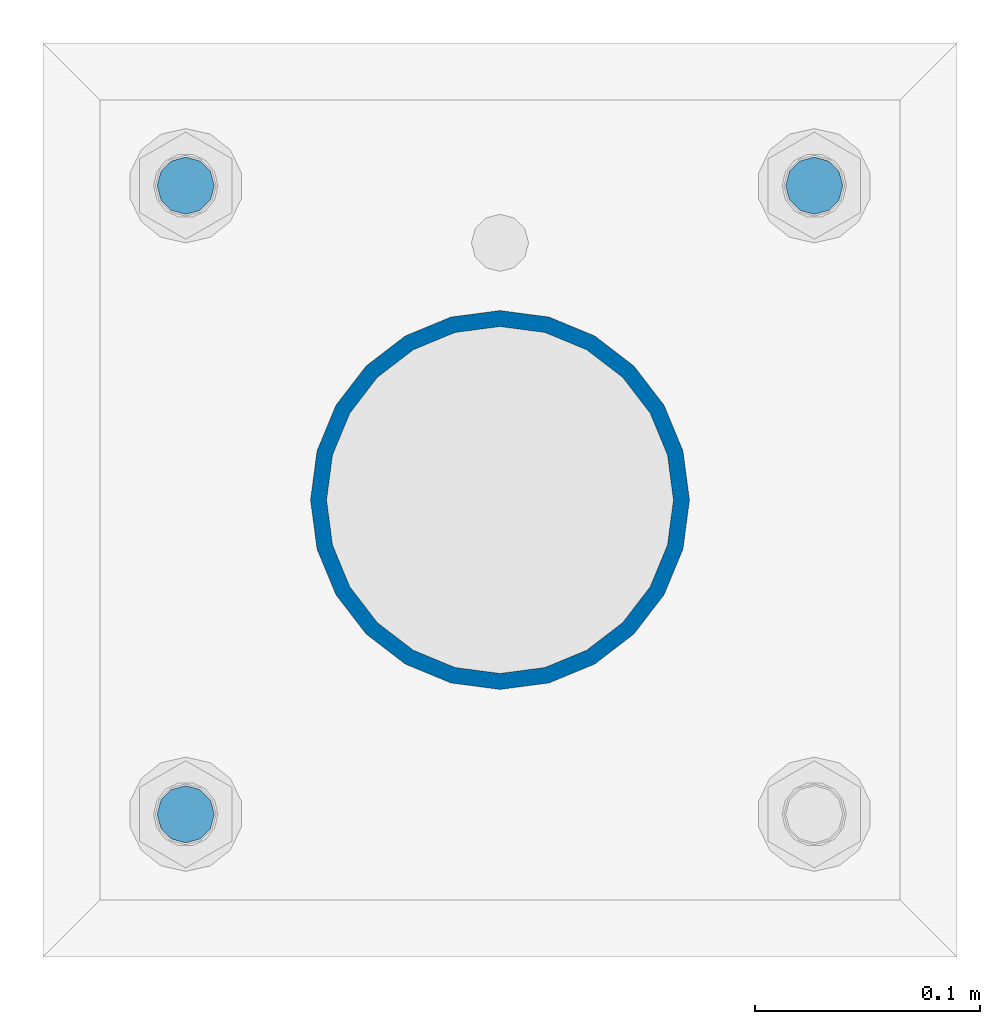
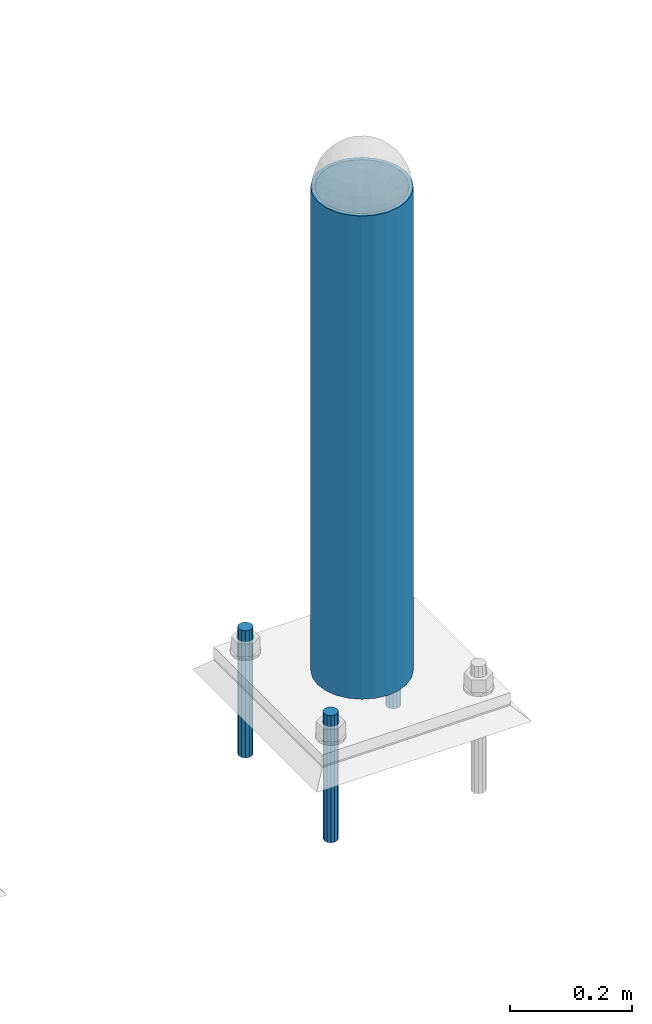
# One storey, part 1441 of 3843: 4 columns, 2 elements without a shape of their own.
"""IFC2X3 building model written with IfcOpenShell, lengths in millimetres."""

from ifc_helpers import new_model, si_unit, frame, origin_with_axes, place, context, subcontext, project, spatial, faceted_brep, material, type_object, element, aggregate, save


model = new_model("IFC2X3")

# Units and contexts
model_context = context("Model", 3, precision=1e-05, world=origin_with_axes())
body_context = subcontext(model_context, "Body", "Model", "MODEL_VIEW")
ifc_project = project(units=[si_unit("LENGTHUNIT", "METRE", prefix="MILLI"), si_unit("AREAUNIT", "SQUARE_METRE"), si_unit("VOLUMEUNIT", "CUBIC_METRE"), si_unit("MASSUNIT", "GRAM", prefix="KILO"), si_unit("TIMEUNIT", "SECOND"), si_unit("PLANEANGLEUNIT", "RADIAN"), si_unit("SOLIDANGLEUNIT", "STERADIAN"), si_unit("THERMODYNAMICTEMPERATUREUNIT", "DEGREE_CELSIUS"), si_unit("LUMINOUSINTENSITYUNIT", "LUMEN")], contexts=[model_context])

# Site, building, storey
site_placement = place(None, origin_with_axes())
site = spatial("IfcSite", under=ifc_project, at=site_placement, CompositionType="ELEMENT")
building_placement = place(site_placement, origin_with_axes())
building = spatial("IfcBuilding", under=site, at=building_placement, Name="Undefined", CompositionType="ELEMENT")
storey_placement = place(building_placement, origin_with_axes())
storey = spatial("IfcBuildingStorey", under=building, at=storey_placement, Name="Undefined", CompositionType="ELEMENT", Elevation=0.0)

# Assembly, column
assembly_1_placement = place(storey_placement, origin_with_axes())
assembly_1 = element("IfcElementAssembly", 1, at=assembly_1_placement, inside=storey, Name="PIPE_BOLLARD", AssemblyPlace="NOTDEFINED", PredefinedType="RIGID_FRAME")
ifc_material_1 = material()
column_type_1 = type_object("IfcColumnType", Name="PIPE6SCH40", PredefinedType="NOTDEFINED")
column_1_placement = place(assembly_1_placement, frame((37106.2721557617, 11565.3447954918, 30480.0), z_axis=(-1.0, 0.0, 0.0), x_axis=(0.0, 0.0, 1.0)))
column_1 = element("IfcColumn", 2, at=column_1_placement, type_object=column_type_1, material=ifc_material_1, Name="PIPE_BOLLARD", ObjectType="PIPE6SCH40", context=body_context, shape_type="Brep", body=[
    faceted_brep([(50.7999999999993, -77.0890000000072, 0.0), (50.7999999999993, -74.4622560228017, 19.9521013679114), (1016.0, -74.4622560228017, 19.9521013679114), (1016.0, -77.0890000000072, 0.0), (50.7999999999993, -66.7610323523404, 38.5445000000036), (1016.0, -66.7610323523404, 38.5445000000036), (50.7999999999993, -54.5101546548831, 54.5101546548904), (1016.0, -54.5101546548831, 54.5101546548904), (50.7999999999993, -38.5445000000036, 66.7610323523404), (1016.0, -38.5445000000036, 66.7610323523404), (50.7999999999993, -19.9521013679041, 74.4622560227945), (1016.0, -19.9521013679041, 74.4622560227945), (50.7999999999993, 0.0, 77.0889999999999), (1016.0, 0.0, 77.0889999999999), (50.7999999999993, 19.9521013679041, 74.4622560227945), (1016.0, 19.9521013679041, 74.4622560227945), (50.7999999999993, 38.5445000000036, 66.7610323523404), (1016.0, 38.5445000000036, 66.7610323523404), (50.7999999999993, 54.5101546548831, 54.5101546548904), (1016.0, 54.5101546548831, 54.5101546548904), (50.7999999999993, 66.7610323523404, 38.5445000000036), (1016.0, 66.7610323523404, 38.5445000000036), (50.7999999999993, 74.4622560228017, 19.9521013679114), (1016.0, 74.4622560228017, 19.9521013679114), (50.7999999999993, 77.0890000000072, 0.0), (1016.0, 77.0890000000072, 0.0), (50.7999999999993, 74.4622560228017, -19.9521013679114), (1016.0, 74.4622560228017, -19.9521013679114), (50.7999999999993, 66.7610323523404, -38.5445000000036), (1016.0, 66.7610323523404, -38.5445000000036), (50.7999999999993, 54.5101546548831, -54.5101546548904), (1016.0, 54.5101546548831, -54.5101546548904), (50.7999999999993, 38.5445000000036, -66.7610323523404), (1016.0, 38.5445000000036, -66.7610323523404), (50.7999999999993, 19.9521013679041, -74.4622560227945), (1016.0, 19.9521013679041, -74.4622560227945), (50.7999999999993, 0.0, -77.0889999999999), (1016.0, 0.0, -77.0889999999999), (50.7999999999993, -19.9521013679041, -74.4622560227945), (1016.0, -19.9521013679041, -74.4622560227945), (50.7999999999993, -38.5445000000036, -66.7610323523404), (1016.0, -38.5445000000036, -66.7610323523404), (50.7999999999993, -54.5101546548831, -54.5101546548904), (1016.0, -54.5101546548831, -54.5101546548904), (50.7999999999993, -66.7610323523404, -38.5445000000036), (1016.0, -66.7610323523404, -38.5445000000036), (50.7999999999993, -74.4622560228017, -19.9521013679114), (1016.0, -74.4622560228017, -19.9521013679114), (50.7999999999993, -84.2010000000009, 0.0), (50.7999999999993, -81.3319204993604, -21.7928224166753), (1016.0, -81.3319204993604, -21.7928224166753), (1016.0, -84.2010000000009, 0.0), (50.7999999999993, -72.9202050240565, -42.1005000000005), (1016.0, -72.9202050240565, -42.1005000000005), (50.7999999999993, -59.5390980826924, -59.5390980826851), (1016.0, -59.5390980826924, -59.5390980826851), (50.7999999999993, -42.1005000000005, -72.9202050240565), (1016.0, -42.1005000000005, -72.9202050240565), (50.7999999999993, -21.7928224166826, -81.3319204993677), (1016.0, -21.7928224166826, -81.3319204993677), (50.7999999999993, 0.0, -84.2010000000009), (1016.0, 0.0, -84.2010000000009), (50.7999999999993, 21.7928224166826, -81.3319204993677), (1016.0, 21.7928224166826, -81.3319204993677), (50.7999999999993, 42.1005000000005, -72.9202050240565), (1016.0, 42.1005000000005, -72.9202050240565), (50.7999999999993, 59.5390980826924, -59.5390980826851), (1016.0, 59.5390980826924, -59.5390980826851), (50.7999999999993, 72.9202050240565, -42.1005000000005), (1016.0, 72.9202050240565, -42.1005000000005), (50.7999999999993, 81.3319204993604, -21.7928224166753), (1016.0, 81.3319204993604, -21.7928224166753), (50.7999999999993, 84.2010000000009, 0.0), (1016.0, 84.2010000000009, 0.0), (50.7999999999993, 81.3319204993604, 21.7928224166753), (1016.0, 81.3319204993604, 21.7928224166753), (50.7999999999993, 72.9202050240565, 42.1005000000005), (1016.0, 72.9202050240565, 42.1005000000005), (50.7999999999993, 59.5390980826924, 59.5390980826851), (1016.0, 59.5390980826924, 59.5390980826851), (50.7999999999993, 42.1005000000005, 72.9202050240565), (1016.0, 42.1005000000005, 72.9202050240565), (50.7999999999993, 21.7928224166826, 81.3319204993677), (1016.0, 21.7928224166826, 81.3319204993677), (50.7999999999993, 0.0, 84.2010000000009), (1016.0, 0.0, 84.2010000000009), (50.7999999999993, -21.7928224166826, 81.3319204993677), (1016.0, -21.7928224166826, 81.3319204993677), (50.7999999999993, -42.1005000000005, 72.9202050240565), (1016.0, -42.1005000000005, 72.9202050240565), (50.7999999999993, -59.5390980826924, 59.5390980826851), (1016.0, -59.5390980826924, 59.5390980826851), (50.7999999999993, -72.9202050240565, 42.1005000000005), (1016.0, -72.9202050240565, 42.1005000000005), (50.7999999999993, -81.3319204993604, 21.7928224166753), (1016.0, -81.3319204993604, 21.7928224166753)], [[[0, 1, 2, 3]], [[1, 4, 5, 2]], [[4, 6, 7, 5]], [[6, 8, 9, 7]], [[8, 10, 11, 9]], [[10, 12, 13, 11]], [[12, 14, 15, 13]], [[14, 16, 17, 15]], [[16, 18, 19, 17]], [[18, 20, 21, 19]], [[20, 22, 23, 21]], [[22, 24, 25, 23]], [[24, 26, 27, 25]], [[26, 28, 29, 27]], [[28, 30, 31, 29]], [[30, 32, 33, 31]], [[32, 34, 35, 33]], [[34, 36, 37, 35]], [[36, 38, 39, 37]], [[38, 40, 41, 39]], [[40, 42, 43, 41]], [[42, 44, 45, 43]], [[44, 46, 47, 45]], [[46, 0, 3, 47]], [[48, 49, 50, 51]], [[49, 52, 53, 50]], [[52, 54, 55, 53]], [[54, 56, 57, 55]], [[56, 58, 59, 57]], [[58, 60, 61, 59]], [[60, 62, 63, 61]], [[62, 64, 65, 63]], [[64, 66, 67, 65]], [[66, 68, 69, 67]], [[68, 70, 71, 69]], [[70, 72, 73, 71]], [[72, 74, 75, 73]], [[74, 76, 77, 75]], [[76, 78, 79, 77]], [[78, 80, 81, 79]], [[80, 82, 83, 81]], [[82, 84, 85, 83]], [[84, 86, 87, 85]], [[86, 88, 89, 87]], [[88, 90, 91, 89]], [[90, 92, 93, 91]], [[92, 94, 95, 93]], [[94, 48, 51, 95]], [[53, 55, 57, 59, 61, 63, 65, 67, 69, 71, 73, 75, 77, 79, 81, 83, 85, 87, 89, 91, 93, 95, 51, 50], [5, 7, 9, 11, 13, 15, 17, 19, 21, 23, 25, 27, 29, 31, 33, 35, 37, 39, 41, 43, 45, 47, 3, 2]], [[94, 92, 90, 88, 86, 84, 82, 80, 78, 76, 74, 72, 70, 68, 66, 64, 62, 60, 58, 56, 54, 52, 49, 48], [46, 44, 42, 40, 38, 36, 34, 32, 30, 28, 26, 24, 22, 20, 18, 16, 14, 12, 10, 8, 6, 4, 1, 0]]]),
])
aggregate(assembly_1, [column_1])

# Assembly, columns
assembly_2_placement = place(storey_placement, origin_with_axes())
assembly_2 = element("IfcElementAssembly", 3, at=assembly_2_placement, inside=storey, Name="TEMPLATE", AssemblyPlace="NOTDEFINED", PredefinedType="RIGID_FRAME")
ifc_material_2 = material(Name="STEEL/316 SS")
column_type_2 = type_object("IfcColumnType", PredefinedType="NOTDEFINED")
column_2_placement = place(assembly_2_placement, frame((37245.9721557617, 11705.0447954918, 30581.6), z_axis=(-1.0, 0.0, 0.0), x_axis=(0.0, 0.0, -1.0)))
column_2 = element("IfcColumn", 4, at=column_2_placement, type_object=column_type_2, material=ifc_material_2, Name="ANCHOR_ROD", context=body_context, shape_type="Brep", body=[
    faceted_brep([(0.0, -12.6999999999971, 0.0), (0.0, -10.9985226280696, -6.34999999999854), (253.999, -10.9985226280696, -6.34999999999854), (253.999, -12.6999999999971, 0.0), (0.0, -6.35000000000582, -10.9985226280623), (253.999, -6.35000000000582, -10.9985226280623), (0.0, 0.0, -12.6999999999971), (253.999, 0.0, -12.6999999999971), (0.0, 6.35000000000582, -10.9985226280623), (253.999, 6.35000000000582, -10.9985226280623), (0.0, 10.9985226280696, -6.34999999999854), (253.999, 10.9985226280696, -6.34999999999854), (0.0, 12.6999999999971, 0.0), (253.999, 12.6999999999971, 0.0), (0.0, 10.9985226280696, 6.34999999999854), (253.999, 10.9985226280696, 6.34999999999854), (0.0, 6.35000000000582, 10.9985226280623), (253.999, 6.35000000000582, 10.9985226280623), (0.0, 0.0, 12.6999999999971), (253.999, 0.0, 12.6999999999971), (0.0, -6.35000000000582, 10.9985226280623), (253.999, -6.35000000000582, 10.9985226280623), (0.0, -10.9985226280696, 6.34999999999854), (253.999, -10.9985226280696, 6.34999999999854)], [[[0, 1, 2, 3]], [[1, 4, 5, 2]], [[4, 6, 7, 5]], [[6, 8, 9, 7]], [[8, 10, 11, 9]], [[10, 12, 13, 11]], [[12, 14, 15, 13]], [[14, 16, 17, 15]], [[16, 18, 19, 17]], [[18, 20, 21, 19]], [[20, 22, 23, 21]], [[22, 0, 3, 23]], [[5, 7, 9, 11, 13, 15, 17, 19, 21, 23, 3, 2]], [[22, 20, 18, 16, 14, 12, 10, 8, 6, 4, 1, 0]]]),
])
column_3_placement = place(assembly_2_placement, frame((36966.5721557617, 11425.6447954918, 30581.6), z_axis=(1.0, 0.0, 0.0), x_axis=(0.0, 0.0, -1.0)))
column_3 = element("IfcColumn", 5, at=column_3_placement, type_object=column_type_2, material=ifc_material_2, Name="ANCHOR_ROD", context=body_context, shape_type="Brep", body=[
    faceted_brep([(0.0, -12.6999999999971, 0.0), (0.0, -10.9985226280696, -6.34999999999854), (253.999, -10.9985226280696, -6.34999999999854), (253.999, -12.6999999999971, 0.0), (0.0, -6.35000000000582, -10.9985226280623), (253.999, -6.35000000000582, -10.9985226280623), (0.0, 0.0, -12.6999999999971), (253.999, 0.0, -12.6999999999971), (0.0, 6.35000000000582, -10.9985226280623), (253.999, 6.35000000000582, -10.9985226280623), (0.0, 10.9985226280696, -6.34999999999854), (253.999, 10.9985226280696, -6.34999999999854), (0.0, 12.6999999999971, 0.0), (253.999, 12.6999999999971, 0.0), (0.0, 10.9985226280696, 6.34999999999854), (253.999, 10.9985226280696, 6.34999999999854), (0.0, 6.35000000000582, 10.9985226280623), (253.999, 6.35000000000582, 10.9985226280623), (0.0, 0.0, 12.6999999999971), (253.999, 0.0, 12.6999999999971), (0.0, -6.35000000000582, 10.9985226280623), (253.999, -6.35000000000582, 10.9985226280623), (0.0, -10.9985226280696, 6.34999999999854), (253.999, -10.9985226280696, 6.34999999999854)], [[[0, 1, 2, 3]], [[1, 4, 5, 2]], [[4, 6, 7, 5]], [[6, 8, 9, 7]], [[8, 10, 11, 9]], [[10, 12, 13, 11]], [[12, 14, 15, 13]], [[14, 16, 17, 15]], [[16, 18, 19, 17]], [[18, 20, 21, 19]], [[20, 22, 23, 21]], [[22, 0, 3, 23]], [[5, 7, 9, 11, 13, 15, 17, 19, 21, 23, 3, 2]], [[22, 20, 18, 16, 14, 12, 10, 8, 6, 4, 1, 0]]]),
])
column_4_placement = place(assembly_2_placement, frame((36966.5721557617, 11705.0447954918, 30581.6), z_axis=(-1.0, 0.0, 0.0), x_axis=(0.0, 0.0, -1.0)))
column_4 = element("IfcColumn", 6, at=column_4_placement, type_object=column_type_2, material=ifc_material_2, Name="ANCHOR_ROD", context=body_context, shape_type="Brep", body=[
    faceted_brep([(0.0, -12.6999999999971, 0.0), (0.0, -10.9985226280696, -6.34999999999854), (253.999, -10.9985226280696, -6.34999999999854), (253.999, -12.6999999999971, 0.0), (0.0, -6.35000000000582, -10.9985226280623), (253.999, -6.35000000000582, -10.9985226280623), (0.0, 0.0, -12.6999999999971), (253.999, 0.0, -12.6999999999971), (0.0, 6.35000000000582, -10.9985226280623), (253.999, 6.35000000000582, -10.9985226280623), (0.0, 10.9985226280696, -6.34999999999854), (253.999, 10.9985226280696, -6.34999999999854), (0.0, 12.6999999999971, 0.0), (253.999, 12.6999999999971, 0.0), (0.0, 10.9985226280696, 6.34999999999854), (253.999, 10.9985226280696, 6.34999999999854), (0.0, 6.35000000000582, 10.9985226280623), (253.999, 6.35000000000582, 10.9985226280623), (0.0, 0.0, 12.6999999999971), (253.999, 0.0, 12.6999999999971), (0.0, -6.35000000000582, 10.9985226280623), (253.999, -6.35000000000582, 10.9985226280623), (0.0, -10.9985226280696, 6.34999999999854), (253.999, -10.9985226280696, 6.34999999999854)], [[[0, 1, 2, 3]], [[1, 4, 5, 2]], [[4, 6, 7, 5]], [[6, 8, 9, 7]], [[8, 10, 11, 9]], [[10, 12, 13, 11]], [[12, 14, 15, 13]], [[14, 16, 17, 15]], [[16, 18, 19, 17]], [[18, 20, 21, 19]], [[20, 22, 23, 21]], [[22, 0, 3, 23]], [[5, 7, 9, 11, 13, 15, 17, 19, 21, 23, 3, 2]], [[22, 20, 18, 16, 14, 12, 10, 8, 6, 4, 1, 0]]]),
])
aggregate(assembly_2, [column_2, column_3, column_4])

save(model, "model.ifc")
